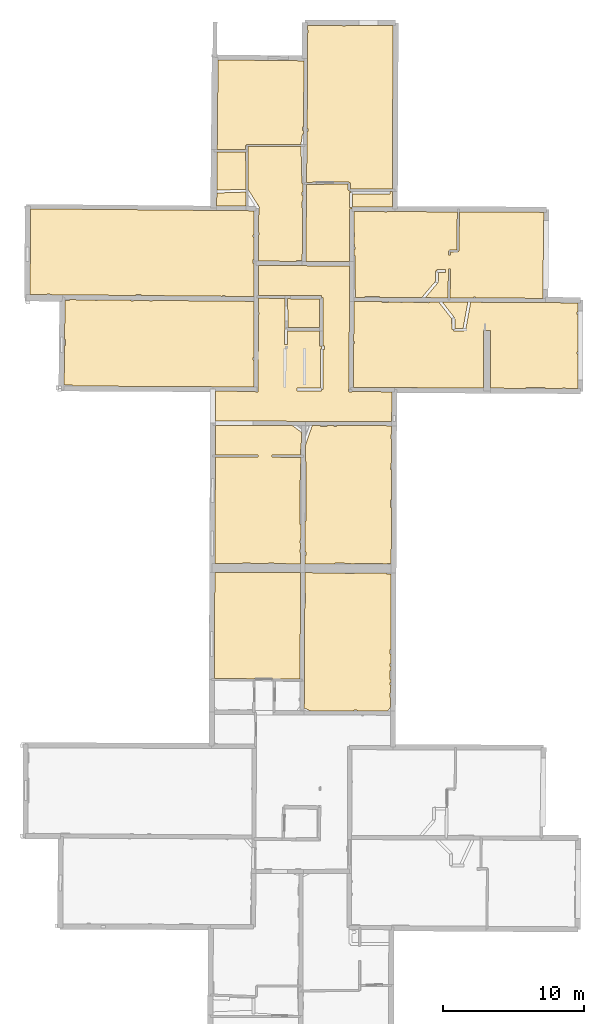
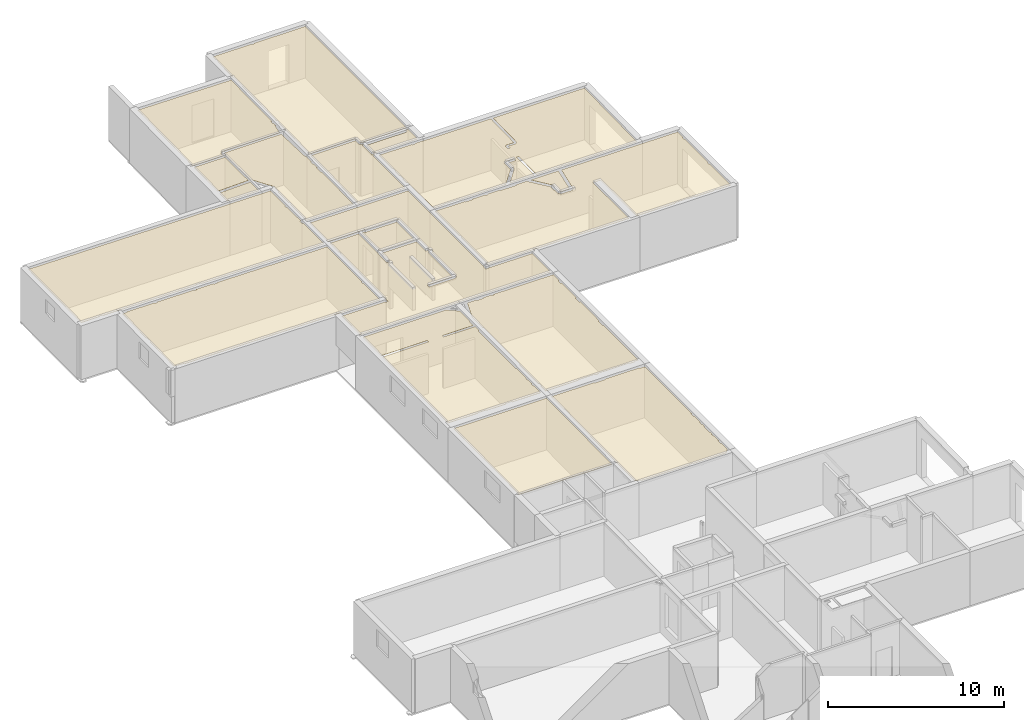
# One storey, part 9 of 12: 18 coverings.
"""IFC2X3 building model written with IfcOpenShell, lengths in metres."""

from ifc_helpers import new_model, entity, si_unit, converted_unit, derived_unit, direction, frame, origin, origin_with_axes, place, context, subcontext, project, spatial, polyline, outline, extrude, material, layer, layer_set, layer_usage, type_object, element, save


model = new_model("IFC2X3")

# Units and contexts
model_context = context("Model", 3, precision=1e-05, world=origin(), true_north=direction((0.0, 1.0)))
body_context = subcontext(model_context, "Body", "Model", "MODEL_VIEW")
ifc_project = project(units=[si_unit("LENGTHUNIT", "METRE"), si_unit("AREAUNIT", "SQUARE_METRE"), si_unit("VOLUMEUNIT", "CUBIC_METRE"), converted_unit("PLANEANGLEUNIT", "DEGREE", entity("IfcRatioMeasure", 0.0174532925199433), si_unit("PLANEANGLEUNIT", "RADIAN"), dimensions=[0, 0, 0, 0, 0, 0, 0]), si_unit("MASSUNIT", "GRAM", prefix="KILO"), derived_unit("MASSDENSITYUNIT", [(si_unit("MASSUNIT", "GRAM", prefix="KILO"), 1), (si_unit("LENGTHUNIT", "METRE"), -3)]), derived_unit("MOMENTOFINERTIAUNIT", [(si_unit("LENGTHUNIT", "METRE"), 4)]), si_unit("TIMEUNIT", "SECOND"), si_unit("FREQUENCYUNIT", "HERTZ"), si_unit("THERMODYNAMICTEMPERATUREUNIT", "DEGREE_CELSIUS"), derived_unit("THERMALTRANSMITTANCEUNIT", [(si_unit("MASSUNIT", "GRAM", prefix="KILO"), 1), (si_unit("THERMODYNAMICTEMPERATUREUNIT", "KELVIN"), -1), (si_unit("TIMEUNIT", "SECOND"), -3)]), derived_unit("VOLUMETRICFLOWRATEUNIT", [(si_unit("LENGTHUNIT", "METRE"), 3), (si_unit("TIMEUNIT", "SECOND"), -1)]), si_unit("ELECTRICCURRENTUNIT", "AMPERE"), si_unit("ELECTRICVOLTAGEUNIT", "VOLT"), si_unit("POWERUNIT", "WATT"), si_unit("FORCEUNIT", "NEWTON", prefix="KILO"), si_unit("ILLUMINANCEUNIT", "LUX"), si_unit("LUMINOUSFLUXUNIT", "LUMEN"), si_unit("LUMINOUSINTENSITYUNIT", "CANDELA"), derived_unit("USERDEFINED", [(si_unit("MASSUNIT", "GRAM", prefix="KILO"), -1), (si_unit("LENGTHUNIT", "METRE"), -2), (si_unit("TIMEUNIT", "SECOND"), 3), (si_unit("LUMINOUSFLUXUNIT", "LUMEN"), 1)]), derived_unit("LINEARVELOCITYUNIT", [(si_unit("LENGTHUNIT", "METRE"), 1), (si_unit("TIMEUNIT", "SECOND"), -1)]), si_unit("PRESSUREUNIT", "PASCAL"), derived_unit("USERDEFINED", [(si_unit("LENGTHUNIT", "METRE"), -2), (si_unit("MASSUNIT", "GRAM", prefix="KILO"), 1), (si_unit("TIMEUNIT", "SECOND"), -2)]), derived_unit("LINEARFORCEUNIT", [(si_unit("MASSUNIT", "GRAM", prefix="KILO"), 1), (si_unit("LENGTHUNIT", "METRE"), 1), (si_unit("TIMEUNIT", "SECOND"), -2), (si_unit("LENGTHUNIT", "METRE"), -1)]), derived_unit("PLANARFORCEUNIT", [(si_unit("MASSUNIT", "GRAM", prefix="KILO"), 1), (si_unit("LENGTHUNIT", "METRE"), 1), (si_unit("TIMEUNIT", "SECOND"), -2), (si_unit("LENGTHUNIT", "METRE"), -2)])], contexts=[model_context])

# Site, building, storey
placement = place(None, origin())
site = spatial("IfcSite", under=ifc_project, at=placement, CompositionType="ELEMENT")
building = spatial("IfcBuilding", under=site, at=placement, CompositionType="ELEMENT")
storey_placement = place(placement, frame((0.0, 0.0, -1.46125340461731)))
storey = spatial("IfcBuildingStorey", under=building, at=storey_placement, Name="Level 1", CompositionType="ELEMENT", Elevation=-1.46125340461731)

# Coverings
ifc_material = material(Name="Covering default")
ifc_layer_1 = layer(ifc_material, 0.02)
ifc_layer_set_1 = layer_set([ifc_layer_1], Name="Covering : 20mm")
ifc_layer_usage_1 = layer_usage(ifc_layer_set_1, "AXIS3", "POSITIVE", 0.0)
covering_type_1 = type_object("IfcCoveringType", Name="Covering : 20mm", PredefinedType="CEILING")
covering_1_placement = place(placement, frame((0.0, 0.0, 2.11485385894775)))
element("IfcCovering", 1, at=covering_1_placement, inside=storey, type_object=covering_type_1, material=ifc_layer_usage_1, Name="Covering : 20mm", ObjectType="Covering : 20mm", PredefinedType="CEILING", context=body_context, shape_type="SweptSolid", body=[
    extrude(outline(polyline([(6.81960868835449, 28.4047565460205), (6.91936683654785, 28.4043636322021), (6.91936683654785, 28.4043636322021), (9.92892074584961, 28.3925189971924), (9.92887115478516, 28.4485511779785), (10.1288719177246, 28.4487266540527), (10.1289215087891, 28.391731262207), (12.295015335083, 28.3832054138184), (12.5214920043945, 28.6799049377441), (12.5238628387451, 29.3308334350586), (12.4680976867676, 29.3307838439941), (12.4678077697754, 29.6607856750488), (12.5250644683838, 29.6608352661133), (12.5270938873291, 30.2176895141602), (12.4673156738281, 30.2207832336426), (12.4771499633789, 30.4107933044434), (12.5277881622314, 30.4081726074219), (12.5286350250244, 30.6408386230469), (12.4769477844238, 30.6407928466797), (12.4763927459717, 31.2707939147949), (12.5309314727783, 31.2708415985107), (12.5319156646729, 31.5408401489258), (12.4761562347412, 31.5407905578613), (12.4759540557861, 31.7707939147949), (12.5327529907227, 31.7708435058594), (12.5352230072021, 32.4488487243652), (12.4753570556641, 32.4507904052734), (12.4850921630859, 32.7508010864258), (12.5363178253174, 32.749137878418), (12.5558586120605, 38.1122245788574), (12.2203636169434, 38.1305694580078), (12.22314453125, 38.1814422607422), (9.95030975341797, 38.192569732666), (9.95035743713379, 38.1385765075684), (9.27035713195801, 38.1379776000977), (9.27030563354492, 38.1958999633789), (6.4320182800293, 38.2097969055176), (6.42446327209473, 36.7662582397461), (6.48156356811523, 36.7655258178711), (6.47220420837402, 36.035514831543), (6.4206428527832, 36.0361747741699), (6.38166809082031, 28.5895862579346), (6.81960868835449, 28.4047565460205)])), origin_with_axes(), (0.0, 0.0, 1.0), 0.02),
])
ifc_layer_2 = layer(ifc_material, 0.02)
ifc_layer_set_2 = layer_set([ifc_layer_2], Name="Covering : 20mm")
ifc_layer_usage_2 = layer_usage(ifc_layer_set_2, "AXIS3", "POSITIVE", 0.0)
covering_type_2 = type_object("IfcCoveringType", Name="Covering : 20mm", PredefinedType="CEILING")
covering_2_placement = place(placement, frame((0.0, 0.0, 2.11485385894775)))
element("IfcCovering", 2, at=covering_2_placement, inside=storey, type_object=covering_type_2, material=ifc_layer_usage_2, Name="Covering : 20mm", ObjectType="Covering : 20mm", PredefinedType="CEILING", context=body_context, shape_type="SweptSolid", body=[
    extrude(outline(polyline([(0.0337352752685547, 38.2411270141602), (6.12202262878418, 38.2113151550293), (6.08241653442383, 30.6440944671631), (4.17814636230469, 30.6672992706299), (4.17814636230469, 30.6672992706299), (2.81326103210449, 30.6839294433594), (2.81315612792969, 30.6753692626953), (-0.00304317474365234, 30.6930713653564), (0.0337352752685547, 38.2411270141602)])), origin_with_axes(), (0.0, 0.0, 1.0), 0.02),
])
ifc_layer_3 = layer(ifc_material, 0.02)
ifc_layer_set_3 = layer_set([ifc_layer_3], Name="Covering : 20mm")
ifc_layer_usage_3 = layer_usage(ifc_layer_set_3, "AXIS3", "POSITIVE", 0.0)
covering_type_3 = type_object("IfcCoveringType", Name="Covering : 20mm", PredefinedType="CEILING")
covering_3_placement = place(placement, frame((0.0, 0.0, 2.11485385894775)))
element("IfcCovering", 3, at=covering_3_placement, inside=storey, type_object=covering_type_3, material=ifc_layer_usage_3, Name="Covering : 20mm", ObjectType="Covering : 20mm", PredefinedType="CEILING", context=body_context, shape_type="SweptSolid", body=[
    extrude(outline(polyline([(8.5792236328125, 38.8292922973633), (8.57969665527344, 38.8873710632324), (9.68970680236816, 38.878345489502), (9.68926429748535, 38.8238563537598), (9.94947814941406, 38.822582244873), (9.94970703125, 38.8785743713379), (11.9597148895264, 38.8703422546387), (11.9594783782959, 38.8127403259277), (12.2697658538818, 38.811222076416), (12.2697143554688, 38.8706130981445), (12.5586223602295, 38.8708648681641), (12.5730876922607, 42.8408851623535), (12.5162258148193, 42.8408355712891), (12.5157699584961, 43.3608322143555), (12.5749816894531, 43.3608856201172), (12.5829563140869, 45.5495491027832), (12.5238456726074, 45.550838470459), (12.5334587097168, 45.9908485412598), (12.5845603942871, 45.9897308349609), (12.5907516479492, 47.6890640258789), (12.5319633483887, 47.6908493041992), (12.5416831970215, 48.010856628418), (12.5919170379639, 48.0093307495117), (12.5942401885986, 48.6466102600098), (8.67111206054688, 48.6574745178223), (8.67115592956543, 48.6074562072754), (8.49115753173828, 48.6072998046875), (8.49111366271973, 48.6579742431641), (8.01111221313477, 48.6593017578125), (8.01115798950195, 48.606876373291), (7.54115676879883, 48.6064643859863), (7.54110908508301, 48.6606063842773), (6.9506893157959, 48.662239074707), (6.47961616516113, 47.3040618896484), (6.47329139709473, 46.095760345459), (6.52336311340332, 46.0955657958984), (6.5070629119873, 41.8855514526367), (6.45125770568848, 41.8857688903809), (6.43980598449707, 39.697681427002), (6.49898719787598, 39.6955413818359), (6.48922348022461, 39.425537109375), (6.43839073181152, 39.427375793457), (6.43531608581543, 38.8397903442383), (8.5792236328125, 38.8292922973633)])), origin_with_axes(), (0.0, 0.0, 1.0), 0.02),
])
ifc_layer_4 = layer(ifc_material, 0.02)
ifc_layer_set_4 = layer_set([ifc_layer_4], Name="Covering : 20mm")
ifc_layer_usage_4 = layer_usage(ifc_layer_set_4, "AXIS3", "POSITIVE", 0.0)
covering_type_4 = type_object("IfcCoveringType", Name="Covering : 20mm", PredefinedType="CEILING")
covering_4_placement = place(placement, frame((0.0, 0.0, 2.11485385894775)))
element("IfcCovering", 4, at=covering_4_placement, inside=storey, type_object=covering_type_4, material=ifc_layer_usage_4, Name="Covering : 20mm", ObjectType="Covering : 20mm", PredefinedType="CEILING", context=body_context, shape_type="SweptSolid", body=[
    extrude(outline(polyline([(0.0735931396484375, 46.4210319519043), (3.09649658203125, 46.4193420410156), (3.09658050537109, 46.5693435668945), (0.0743236541748047, 46.5710334777832), (0.0846071243286133, 48.6812591552734), (5.53247451782227, 48.6661682128906), (6.17422676086426, 48.1857299804688), (6.16804885864258, 47.005256652832), (6.11256408691406, 47.0052070617676), (6.11296081542969, 46.5538520812988), (4.10018730163574, 46.5630912780762), (4.0994987487793, 46.4130935668945), (6.1648998260498, 46.4036140441895), (6.16255187988281, 45.9549789428711), (6.10348701477051, 45.9552001953125), (6.0872917175293, 41.6251792907715), (6.13988876342773, 41.6249809265137), (6.13397598266602, 40.4952239990234), (6.07828330993652, 40.495174407959), (6.07842445373535, 40.3351745605469), (6.13313865661621, 40.3352241516113), (6.1307315826416, 39.8752174377441), (6.07882881164551, 39.875171661377), (6.07902145385742, 39.6551742553711), (6.12957954406738, 39.6552200317383), (6.12531852722168, 38.84130859375), (4.23972702026367, 38.8505401611328), (4.23968124389648, 38.9035568237305), (3.82968139648438, 38.9031982421875), (3.82972526550293, 38.8525466918945), (2.56972312927246, 38.8587188720703), (2.56967544555664, 38.9120903015137), (1.98967361450195, 38.9115791320801), (1.98971748352051, 38.8615570068359), (0.0368051528930664, 38.8711204528809), (0.0735931396484375, 46.4210319519043)])), origin_with_axes(), (0.0, 0.0, 1.0), 0.02),
])
ifc_layer_5 = layer(ifc_material, 0.02)
ifc_layer_set_5 = layer_set([ifc_layer_5], Name="Covering : 20mm")
ifc_layer_usage_5 = layer_usage(ifc_layer_set_5, "AXIS3", "POSITIVE", 0.0)
covering_type_5 = type_object("IfcCoveringType", Name="Covering : 20mm", PredefinedType="CEILING")
covering_5_placement = place(placement, frame((0.0, 0.0, 2.11485385894775)))
element("IfcCovering", 5, at=covering_5_placement, inside=storey, type_object=covering_type_5, material=ifc_layer_usage_5, Name="Covering : 20mm", ObjectType="Covering : 20mm", PredefinedType="CEILING", context=body_context, shape_type="SweptSolid", body=[
    extrude(outline(polyline([(0.093693733215332, 51.1060333251953), (2.91269683837891, 51.0909042358398), (2.91271209716797, 51.0544128417969), (3.11271286010742, 51.0544967651367), (3.11943244934082, 56.5325813293457), (3.17419052124023, 56.5326271057129), (3.17404937744141, 56.692626953125), (3.11959457397461, 56.6925773620605), (3.12062072753906, 57.7068061828613), (5.00742530822754, 57.6975631713867), (5.01827812194824, 55.508918762207), (4.99913787841797, 55.5091552734375), (4.98565864562988, 54.4176330566406), (5.18564414978027, 54.4151649475098), (5.19758987426758, 55.3826217651367), (7.48031997680664, 55.3757209777832), (7.48015403747559, 54.3185348510742), (7.61214637756348, 54.3185157775879), (7.61680030822754, 54.114429473877), (7.52385520935059, 54.1143608093262), (7.52589988708496, 51.3278465270996), (5.86647987365723, 51.3314819335938), (5.86604118347168, 51.1314811706543), (7.62575531005859, 51.1276245117188), (7.62597465515137, 51.2276229858398), (7.72597503662109, 51.2276954650879), (7.72388648986816, 54.0700416564941), (7.81781387329102, 54.0721817016602), (7.81234359741211, 54.3121185302734), (7.73015213012695, 54.310245513916), (7.73069381713867, 57.7598152160645), (7.60569381713867, 57.7598342895508), (7.60630798339844, 57.8848304748535), (5.42375183105469, 57.8955192565918), (5.42375183105469, 57.8955230712891), (5.00743103027344, 57.8975639343262), (5.00743103027344, 57.8975639343262), (3.12082290649414, 57.9068069458008), (3.12297058105469, 60.0285987854004), (6.23430252075195, 60.0130310058594), (9.59222984313965, 59.9962348937988), (9.56819343566895, 51.2703552246094), (9.53402709960938, 51.2704429626465), (9.53350448608398, 51.070442199707), (9.55812835693359, 51.0703773498535), (9.55806732177734, 51.0596885681152), (9.75806427001953, 51.0585327148438), (9.75815391540527, 51.0740432739258), (12.60302734375, 51.0580978393555), (12.5953330993652, 48.9466094970703), (6.48793029785156, 48.9635238647461), (0.085357666015625, 48.981258392334), (0.093693733215332, 51.1060333251953)])), origin_with_axes(), (0.0, 0.0, 1.0), 0.02),
])
ifc_layer_6 = layer(ifc_material, 0.02)
ifc_layer_set_6 = layer_set([ifc_layer_6], Name="Covering : 20mm")
ifc_layer_usage_6 = layer_usage(ifc_layer_set_6, "AXIS3", "POSITIVE", 0.0)
covering_type_6 = type_object("IfcCoveringType", Name="Covering : 20mm", PredefinedType="CEILING")
covering_6_placement = place(placement, frame((0.0, 0.0, 2.11485385894775)))
element("IfcCovering", 6, at=covering_6_placement, inside=storey, type_object=covering_type_6, material=ifc_layer_usage_6, Name="Covering : 20mm", ObjectType="Covering : 20mm", PredefinedType="CEILING", context=body_context, shape_type="SweptSolid", body=[
    extrude(outline(polyline([(9.89705848693848, 54.4885330200195), (9.95598983764648, 54.4885864257812), (9.95585632324219, 54.6385879516602), (9.8974723815918, 54.6385383605957), (9.90526390075684, 57.4678573608398), (11.8933811187744, 57.4572677612305), (11.8934307098389, 57.4002914428711), (12.3734302520752, 57.4007110595703), (12.3733825683594, 57.4547119140625), (13.2033843994141, 57.4502906799316), (13.2034378051758, 57.3914413452148), (13.3734397888184, 57.3915939331055), (13.3733882904053, 57.4493865966797), (14.1438751220703, 57.4452819824219), (14.143440246582, 57.3922653198242), (15.2434463500977, 57.3832321166992), (15.2439079284668, 57.4394226074219), (15.9331817626953, 57.4357528686523), (16.8244094848633, 56.2875328063965), (16.824764251709, 55.8846206665039), (16.8808116912842, 55.8846702575684), (16.8757820129395, 55.4692268371582), (16.9757747650146, 55.4680137634277), (16.974910736084, 55.3680191040039), (16.974910736084, 55.3680191040039), (16.974910736084, 55.3680191040039), (17.7444438934326, 55.3613739013672), (17.7453079223633, 55.461368560791), (17.843692779541, 55.4434661865234), (18.203987121582, 57.423656463623), (25.8156967163086, 57.3757781982422), (25.815673828125, 56.7425231933594), (25.7640151977539, 56.7424774169922), (25.7641830444336, 56.5524787902832), (25.8156661987305, 56.5525245666504), (25.8155632019043, 53.9025268554688), (25.7565078735352, 53.902473449707), (25.7566604614258, 53.7324714660645), (25.8155555725098, 53.7325248718262), (25.8154602050781, 51.2824859619141), (24.9488105773926, 51.2871894836426), (24.9487609863281, 51.3417625427246), (24.7087631225586, 51.3415489196777), (24.7088088989258, 51.2884941101074), (23.4683799743652, 51.2952270507812), (23.46875, 51.3504600524902), (22.1487426757812, 51.3592987060547), (22.1483612060547, 51.3023910522461), (19.6181602478027, 51.3161277770996), (19.6195487976074, 55.4235000610352), (19.1295471191406, 55.4236640930176), (19.1281585693359, 51.318790435791), (9.88847732543945, 51.3733177185059), (9.89705848693848, 54.4885330200195)])), origin_with_axes(), (0.0, 0.0, 1.0), 0.02),
])
ifc_layer_7 = layer(ifc_material, 0.02)
ifc_layer_set_7 = layer_set([ifc_layer_7], Name="Covering : 20mm")
ifc_layer_usage_7 = layer_usage(ifc_layer_set_7, "AXIS3", "POSITIVE", 0.0)
covering_type_7 = type_object("IfcCoveringType", Name="Covering : 20mm", PredefinedType="CEILING")
covering_7_placement = place(placement, frame((0.0, 0.0, 2.11485385894775)))
element("IfcCovering", 7, at=covering_7_placement, inside=storey, type_object=covering_type_7, material=ifc_layer_usage_7, Name="Covering : 20mm", ObjectType="Covering : 20mm", PredefinedType="CEILING", context=body_context, shape_type="SweptSolid", body=[
    extrude(outline(polyline([(-10.6423006057739, 54.3604850769043), (-10.5839080810547, 54.3605346679688), (-10.5842761993408, 54.7805366516113), (-10.6380653381348, 54.7804908752441), (-10.6101312637329, 57.5505142211914), (-10.2967090606689, 57.5507888793945), (-10.2967529296875, 57.6007919311523), (-8.47673988342285, 57.5846138000488), (-8.47669219970703, 57.5323867797852), (-8.29669189453125, 57.5325469970703), (-8.29673671722412, 57.5830116271973), (-5.92671966552734, 57.5619430541992), (-5.92666864395142, 57.5046310424805), (-5.75666809082031, 57.5047836303711), (-5.75671768188477, 57.560432434082), (-4.61670684814453, 57.5502967834473), (-4.61665916442871, 57.4957809448242), (-4.38665962219238, 57.4959869384766), (-4.38670635223389, 57.5482521057129), (2.80591011047363, 57.4843101501465), (2.80635452270508, 53.4923057556152), (2.74686050415039, 53.4922523498535), (2.74700164794922, 53.3322525024414), (2.80619239807129, 53.3323059082031), (2.80423927307129, 51.4014930725098), (-10.0449123382568, 51.4704780578613), (-10.041410446167, 51.5210113525391), (-10.6704959869385, 51.5646057128906), (-10.6423006057739, 54.3604850769043)])), origin_with_axes(), (0.0, 0.0, 1.0), 0.02),
])
ifc_layer_8 = layer(ifc_material, 0.02)
ifc_layer_set_8 = layer_set([ifc_layer_8], Name="Covering : 20mm")
ifc_layer_usage_8 = layer_usage(ifc_layer_set_8, "AXIS3", "POSITIVE", 0.0)
covering_type_8 = type_object("IfcCoveringType", Name="Covering : 20mm", PredefinedType="CEILING")
covering_8_placement = place(placement, frame((0.0, 0.0, 2.11485385894775)))
element("IfcCovering", 8, at=covering_8_placement, inside=storey, type_object=covering_type_8, material=ifc_layer_usage_8, Name="Covering : 20mm", ObjectType="Covering : 20mm", PredefinedType="CEILING", context=body_context, shape_type="SweptSolid", body=[
    extrude(outline(polyline([(17.0641574859619, 56.3048324584961), (16.9851570129395, 56.2435150146484), (17.0851554870605, 56.242301940918), (17.0769824981689, 55.5671463012695), (17.6619930267334, 55.5620956420898), (18.0008983612061, 57.4247398376465), (16.1874084472656, 57.434398651123), (17.0641574859619, 56.3048324584961)])), origin_with_axes(), (0.0, 0.0, 1.0), 0.02),
])
ifc_layer_9 = layer(ifc_material, 0.02)
ifc_layer_set_9 = layer_set([ifc_layer_9], Name="Covering : 20mm")
ifc_layer_usage_9 = layer_usage(ifc_layer_set_9, "AXIS3", "POSITIVE", 0.0)
covering_type_9 = type_object("IfcCoveringType", Name="Covering : 20mm", PredefinedType="CEILING")
covering_9_placement = place(placement, frame((0.0, 0.0, 2.11485385894775)))
element("IfcCovering", 9, at=covering_9_placement, inside=storey, type_object=covering_type_9, material=ifc_layer_usage_9, Name="Covering : 20mm", ObjectType="Covering : 20mm", PredefinedType="CEILING", context=body_context, shape_type="SweptSolid", body=[
    extrude(outline(polyline([(5.21766662597656, 55.6325607299805), (7.48036003112793, 55.6257209777832), (7.48067474365234, 57.6354446411133), (5.42252731323242, 57.6455230712891), (5.42277145385742, 57.6955261230469), (5.20743370056152, 57.6965827941895), (5.21766662597656, 55.6325607299805)])), origin_with_axes(), (0.0, 0.0, 1.0), 0.02),
])
ifc_layer_10 = layer(ifc_material, 0.02)
ifc_layer_set_10 = layer_set([ifc_layer_10], Name="Covering : 20mm")
ifc_layer_usage_10 = layer_usage(ifc_layer_set_10, "AXIS3", "POSITIVE", 0.0)
covering_type_10 = type_object("IfcCoveringType", Name="Covering : 20mm", PredefinedType="CEILING")
covering_10_placement = place(placement, frame((0.0, 0.0, 2.11485385894775)))
element("IfcCovering", 10, at=covering_10_placement, inside=storey, type_object=covering_type_10, material=ifc_layer_usage_10, Name="Covering : 20mm", ObjectType="Covering : 20mm", PredefinedType="CEILING", context=body_context, shape_type="SweptSolid", body=[
    extrude(outline(polyline([(9.91545867919922, 61.1685523986816), (9.97011947631836, 61.1686019897461), (9.96978378295898, 61.5486030578613), (9.91650581359863, 61.5485572814941), (9.91790962219238, 62.0585556030273), (9.96933746337891, 62.0586013793945), (9.96907424926758, 62.3586006164551), (9.91873550415039, 62.3585548400879), (9.92292594909668, 63.8801612854004), (12.0977439880371, 63.8724403381348), (12.0977897644043, 63.8204765319824), (12.2777881622314, 63.8206367492676), (12.2777423858643, 63.8717994689941), (12.8263969421387, 63.8698539733887), (12.8263378143311, 63.8565330505371), (17.2570781707764, 63.8369636535645), (17.2176780700684, 61.1217460632324), (16.6900329589844, 61.1293334960938), (16.6890468597412, 61.060848236084), (16.6140575408936, 61.0597991943359), (16.6179294586182, 60.783447265625), (16.7679138183594, 60.7855491638184), (16.7650318145752, 60.9912643432617), (17.2906894683838, 60.9837036132812), (17.2916736602783, 61.0521850585938), (17.3666687011719, 61.0510940551758), (17.4070835113525, 63.8362998962402), (23.4003295898438, 63.8098335266113), (23.3235855102539, 57.6963958740234), (18.543155670166, 57.7218551635742), (18.5431060791016, 57.7761383056641), (18.3931045532227, 57.7760009765625), (18.3931541442871, 57.72265625), (16.7444725036621, 57.7314338684082), (16.771951675415, 59.784294128418), (16.6219654083252, 59.7863006591797), (16.5944690704346, 57.732234954834), (14.981086730957, 57.7408256530762), (15.8879547119141, 58.8126335144043), (15.8116130828857, 58.8772277832031), (15.9116153717041, 58.8771057128906), (15.9124221801758, 59.5424957275391), (16.41383934021, 59.5433502197266), (16.4134979248047, 59.743350982666), (15.812370300293, 59.7423286437988), (15.8125419616699, 59.6423187255859), (15.7125434875488, 59.6424407958984), (15.7116603851318, 58.9139099121094), (14.7202777862549, 57.7422142028809), (11.732608795166, 57.758129119873), (11.7330703735352, 57.8101501464844), (10.7030620574951, 57.8192443847656), (10.7025699615479, 57.763614654541), (10.0138130187988, 57.7672843933105), (9.97050476074219, 60.7285995483398), (9.91424369812012, 60.7277755737305), (9.91545867919922, 61.1685523986816)])), origin_with_axes(), (0.0, 0.0, 1.0), 0.02),
])
ifc_layer_11 = layer(ifc_material, 0.02)
ifc_layer_set_11 = layer_set([ifc_layer_11], Name="Covering : 20mm")
ifc_layer_usage_11 = layer_usage(ifc_layer_set_11, "AXIS3", "POSITIVE", 0.0)
covering_type_11 = type_object("IfcCoveringType", Name="Covering : 20mm", PredefinedType="CEILING")
covering_11_placement = place(placement, frame((0.0, 0.0, 2.11485385894775)))
element("IfcCovering", 11, at=covering_11_placement, inside=storey, type_object=covering_type_11, material=ifc_layer_usage_11, Name="Covering : 20mm", ObjectType="Covering : 20mm", PredefinedType="CEILING", context=body_context, shape_type="SweptSolid", body=[
    extrude(outline(polyline([(-13.0520610809326, 64.0572814941406), (0.159889221191406, 63.9379997253418), (0.159889221191406, 63.9379997253418), (2.81690216064453, 63.9140129089355), (2.81517028808594, 62.2023162841797), (2.75920677185059, 62.2022666931152), (2.75934791564941, 62.0422668457031), (2.81500816345215, 62.0423164367676), (2.81341934204102, 60.4723129272461), (2.76072692871094, 60.4722671508789), (2.7609806060791, 60.1848220825195), (2.81312942504883, 60.1848678588867), (2.81073951721191, 57.8242797851562), (0.763038635253906, 57.8424835205078), (0.76298713684082, 57.9005126953125), (0.562986373901367, 57.900333404541), (0.563036918640137, 57.8442611694336), (-5.1970100402832, 57.8954658508301), (-5.19706153869629, 57.9552726745605), (-5.57706260681152, 57.9549407958984), (-5.57701396942139, 57.8988456726074), (-10.801362991333, 57.9452896118164), (-10.801362991333, 57.9452934265137), (-11.6570634841919, 57.9528999328613), (-11.6571140289307, 58.0095977783203), (-11.8971099853516, 58.0093841552734), (-11.8970613479614, 57.9550323486328), (-13.0909366607666, 57.9656448364258), (-13.0520610809326, 64.0572814941406)])), origin_with_axes(), (0.0, 0.0, 1.0), 0.02),
])
ifc_layer_12 = layer(ifc_material, 0.02)
ifc_layer_set_12 = layer_set([ifc_layer_12], Name="Covering : 20mm")
ifc_layer_usage_12 = layer_usage(ifc_layer_set_12, "AXIS3", "POSITIVE", 0.0)
covering_type_12 = type_object("IfcCoveringType", Name="Covering : 20mm", PredefinedType="CEILING")
covering_12_placement = place(placement, frame((0.0, 0.0, 2.11485385894775)))
element("IfcCovering", 12, at=covering_12_placement, inside=storey, type_object=covering_type_12, material=ifc_layer_usage_12, Name="Covering : 20mm", ObjectType="Covering : 20mm", PredefinedType="CEILING", context=body_context, shape_type="SweptSolid", body=[
    extrude(outline(polyline([(6.54706573486328, 65.7853088378906), (6.41866874694824, 65.7864990234375), (9.48969078063965, 65.8166122436523), (9.48869705200195, 65.3779525756836), (9.57041549682617, 65.3777694702148), (9.57024383544922, 65.3027648925781), (9.70612525939941, 65.3024597167969), (9.70565032958984, 65.2063446044922), (9.60565185546875, 65.2070465087891), (9.59834671020508, 64.1655044555664), (9.76381492614746, 64.1643447875977), (9.76333999633789, 64.0307312011719), (9.60334205627441, 64.0311737060547), (9.59308433532715, 60.3062362670898), (6.49650955200195, 60.3217239379883), (6.54706573486328, 65.7853088378906)])), origin_with_axes(), (0.0, 0.0, 1.0), 0.02),
])
ifc_layer_13 = layer(ifc_material, 0.02)
ifc_layer_set_13 = layer_set([ifc_layer_13], Name="Covering : 20mm")
ifc_layer_usage_13 = layer_usage(ifc_layer_set_13, "AXIS3", "POSITIVE", 0.0)
covering_type_13 = type_object("IfcCoveringType", Name="Covering : 20mm", PredefinedType="CEILING")
covering_13_placement = place(placement, frame((0.0, 0.0, 2.11485385894775)))
element("IfcCovering", 13, at=covering_13_placement, inside=storey, type_object=covering_type_13, material=ifc_layer_usage_13, Name="Covering : 20mm", ObjectType="Covering : 20mm", PredefinedType="CEILING", context=body_context, shape_type="SweptSolid", body=[
    extrude(outline(polyline([(2.38611602783203, 65.4302368164062), (2.39604759216309, 65.4364547729492), (3.09037780761719, 64.3276901245117), (3.12732315063477, 64.3276519775391), (3.12726402282715, 64.2687835693359), (3.21778297424316, 64.1242370605469), (3.17753982543945, 64.0990371704102), (3.17797660827637, 63.6026344299316), (3.12658882141113, 63.6025886535645), (3.1253547668457, 62.3825912475586), (3.17904853820801, 62.3826370239258), (3.17919921875, 62.2126350402832), (3.12518119812012, 62.212589263916), (3.1232852935791, 60.3386001586914), (5.82879257202148, 60.325065612793), (5.8308048248291, 60.3849639892578), (6.23695755004883, 60.3713150024414), (6.27141761779785, 64.0953521728516), (6.21754455566406, 64.0953063964844), (6.21711349487305, 64.5853042602539), (6.27595138549805, 64.5853576660156), (6.2796516418457, 64.9853591918945), (6.22676277160645, 64.9853134155273), (6.22652435302734, 65.2553100585938), (6.28215026855469, 65.2553558349609), (6.28774261474609, 65.8597106933594), (6.21949768066406, 65.8579635620117), (6.15221405029297, 68.4848480224609), (2.37452697753906, 68.4855117797852), (2.38611602783203, 65.4302368164062)])), origin_with_axes(), (0.0, 0.0, 1.0), 0.02),
])
ifc_layer_14 = layer(ifc_material, 0.02)
ifc_layer_set_14 = layer_set([ifc_layer_14], Name="Covering : 20mm")
ifc_layer_usage_14 = layer_usage(ifc_layer_set_14, "AXIS3", "POSITIVE", 0.0)
covering_type_14 = type_object("IfcCoveringType", Name="Covering : 20mm", PredefinedType="CEILING")
covering_14_placement = place(placement, frame((0.0, 0.0, 2.11485385894775)))
element("IfcCovering", 14, at=covering_14_placement, inside=storey, type_object=covering_type_14, material=ifc_layer_usage_14, Name="Covering : 20mm", ObjectType="Covering : 20mm", PredefinedType="CEILING", context=body_context, shape_type="SweptSolid", body=[
    extrude(outline(polyline([(9.80494689941406, 65.1058502197266), (12.4634895324707, 65.0926818847656), (12.4644966125488, 65.2961883544922), (12.642240524292, 65.295783996582), (12.6376762390137, 64.170524597168), (9.7984561920166, 64.1806106567383), (9.80494689941406, 65.1058502197266)])), origin_with_axes(), (0.0, 0.0, 1.0), 0.02),
])
ifc_layer_15 = layer(ifc_material, 0.02)
ifc_layer_set_15 = layer_set([ifc_layer_15], Name="Covering : 20mm")
ifc_layer_usage_15 = layer_usage(ifc_layer_set_15, "AXIS3", "POSITIVE", 0.0)
covering_type_15 = type_object("IfcCoveringType", Name="Covering : 20mm", PredefinedType="CEILING")
covering_15_placement = place(placement, frame((0.0, 0.0, 2.11485385894775)))
element("IfcCovering", 15, at=covering_15_placement, inside=storey, type_object=covering_type_15, material=ifc_layer_usage_15, Name="Covering : 20mm", ObjectType="Covering : 20mm", PredefinedType="CEILING", context=body_context, shape_type="SweptSolid", body=[
    extrude(outline(polyline([(0.171646118164062, 65.1782073974609), (2.23682403564453, 65.2435684204102), (2.24063301086426, 64.2392196655273), (0.162860870361328, 64.2579803466797), (0.171646118164062, 65.1782073974609)])), origin_with_axes(), (0.0, 0.0, 1.0), 0.02),
])
ifc_layer_16 = layer(ifc_material, 0.02)
ifc_layer_set_16 = layer_set([ifc_layer_16], Name="Covering : 20mm")
ifc_layer_usage_16 = layer_usage(ifc_layer_set_16, "AXIS3", "POSITIVE", 0.0)
covering_type_16 = type_object("IfcCoveringType", Name="Covering : 20mm", PredefinedType="CEILING")
covering_16_placement = place(placement, frame((0.0, 0.0, 2.11485385894775)))
element("IfcCovering", 16, at=covering_16_placement, inside=storey, type_object=covering_type_16, material=ifc_layer_usage_16, Name="Covering : 20mm", ObjectType="Covering : 20mm", PredefinedType="CEILING", context=body_context, shape_type="SweptSolid", body=[
    extrude(outline(polyline([(0.199585914611816, 68.1049346923828), (2.22597885131836, 68.1019897460938), (2.23606300354004, 65.4436416625977), (0.173557281494141, 65.3783645629883), (0.199585914611816, 68.1049346923828)])), origin_with_axes(), (0.0, 0.0, 1.0), 0.02),
])
ifc_layer_17 = layer(ifc_material, 0.02)
ifc_layer_set_17 = layer_set([ifc_layer_17], Name="Covering : 20mm")
ifc_layer_usage_17 = layer_usage(ifc_layer_set_17, "AXIS3", "POSITIVE", 0.0)
covering_type_17 = type_object("IfcCoveringType", Name="Covering : 20mm", PredefinedType="CEILING")
covering_17_placement = place(placement, frame((0.0, 0.0, 2.11485385894775)))
element("IfcCovering", 17, at=covering_17_placement, inside=storey, type_object=covering_type_17, material=ifc_layer_usage_17, Name="Covering : 20mm", ObjectType="Covering : 20mm", PredefinedType="CEILING", context=body_context, shape_type="SweptSolid", body=[
    extrude(outline(polyline([(6.57342147827148, 68.6335906982422), (6.57342147827148, 68.6335906982422), (6.58188438415527, 69.5481643676758), (6.63275527954102, 69.5456695556641), (6.642578125, 69.7456817626953), (6.58373832702637, 69.7485733032227), (6.62995719909668, 74.7431411743164), (6.59722137451172, 74.7434463500977), (6.60554504394531, 76.5580825805664), (6.65659523010254, 76.5556945800781), (6.66641044616699, 76.7657012939453), (6.60651016235352, 76.7685012817383), (6.60796165466309, 77.0849227905273), (9.11613655090332, 77.0786666870117), (9.11618041992188, 77.0278625488281), (9.31618118286133, 77.0280380249023), (9.31613731384277, 77.0781707763672), (12.6900081634521, 77.0697555541992), (12.6428489685059, 65.4457855224609), (9.65230751037598, 65.4525833129883), (9.65330505371094, 65.892219543457), (9.57158279418945, 65.8924102783203), (9.57084655761719, 65.967414855957), (6.54847717285156, 65.9377746582031), (6.57342147827148, 68.6335906982422)])), origin_with_axes(), (0.0, 0.0, 1.0), 0.02),
])
ifc_layer_18 = layer(ifc_material, 0.02)
ifc_layer_set_18 = layer_set([ifc_layer_18], Name="Covering : 20mm")
ifc_layer_usage_18 = layer_usage(ifc_layer_set_18, "AXIS3", "POSITIVE", 0.0)
covering_type_18 = type_object("IfcCoveringType", Name="Covering : 20mm", PredefinedType="CEILING")
covering_18_placement = place(placement, frame((0.0, 0.0, 2.11485385894775)))
element("IfcCovering", 18, at=covering_18_placement, inside=storey, type_object=covering_type_18, material=ifc_layer_usage_18, Name="Covering : 20mm", ObjectType="Covering : 20mm", PredefinedType="CEILING", context=body_context, shape_type="SweptSolid", body=[
    extrude(outline(polyline([(0.261943817138672, 74.6370620727539), (6.36830520629883, 74.5658645629883), (6.32469749450684, 69.8532257080078), (6.27248382568359, 69.855354309082), (6.2626953125, 69.6153411865234), (6.32247352600098, 69.612907409668), (6.32028579711914, 69.3763809204102), (6.26289749145508, 69.3853454589844), (6.1456356048584, 68.6348495483398), (2.29925346374512, 68.6355285644531), (2.29924011230469, 68.5605163574219), (2.22424125671387, 68.5602340698242), (2.22541046142578, 68.2519912719727), (0.201018333435059, 68.2549362182617), (0.261943817138672, 74.6370620727539)])), origin_with_axes(), (0.0, 0.0, 1.0), 0.02),
])

save(model, "model.ifc")
